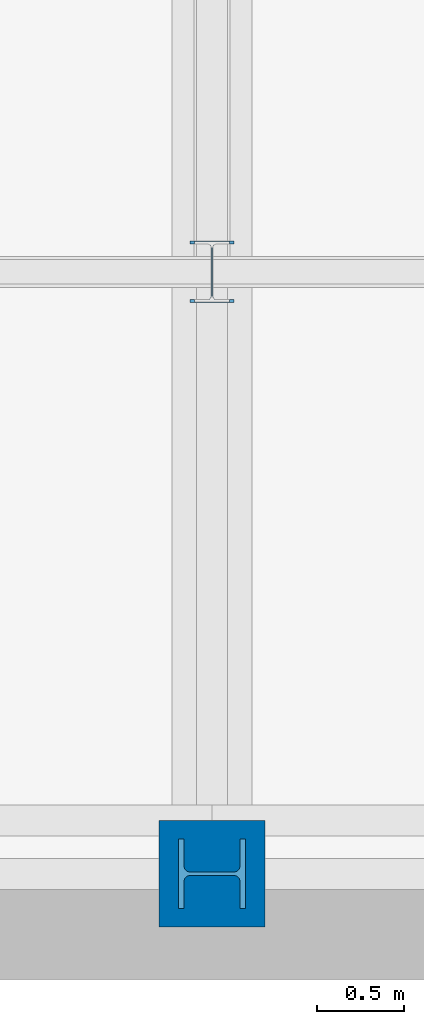
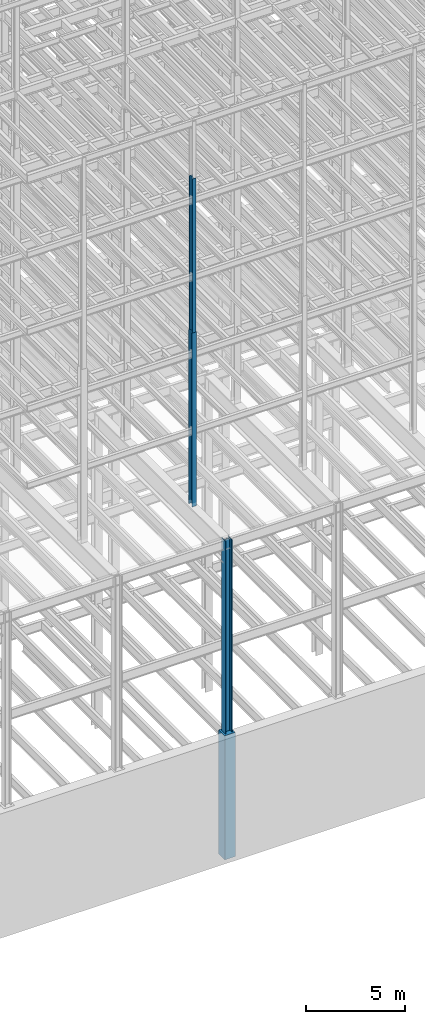
# One storey, part 5 of 150: 4 columns.
"""IFC2X3 building model written with IfcOpenShell, lengths in millimetres."""

from ifc_helpers import new_model, si_unit, frame, origin_with_axes, origin_2d_with_axis, place, context, subcontext, project, spatial, rectangle, i_section, extrude, material, type_object, element, save


model = new_model("IFC2X3")

# Units and contexts
model_context = context("Model", 3, precision=1e-05, world=origin_with_axes())
body_context = subcontext(model_context, "Body", "Model", "MODEL_VIEW")
ifc_project = project(units=[si_unit("LENGTHUNIT", "METRE", prefix="MILLI"), si_unit("AREAUNIT", "SQUARE_METRE"), si_unit("VOLUMEUNIT", "CUBIC_METRE"), si_unit("MASSUNIT", "GRAM", prefix="KILO"), si_unit("TIMEUNIT", "SECOND"), si_unit("PLANEANGLEUNIT", "RADIAN"), si_unit("SOLIDANGLEUNIT", "STERADIAN"), si_unit("THERMODYNAMICTEMPERATUREUNIT", "DEGREE_CELSIUS"), si_unit("LUMINOUSINTENSITYUNIT", "LUMEN")], contexts=[model_context])

# Site, building, storey
site_placement = place(None, origin_with_axes())
site = spatial("IfcSite", under=ifc_project, at=site_placement, CompositionType="ELEMENT")
building_placement = place(site_placement, origin_with_axes())
building = spatial("IfcBuilding", under=site, at=building_placement, Name="Undefined", CompositionType="ELEMENT")
storey_placement = place(building_placement, origin_with_axes())
storey = spatial("IfcBuildingStorey", under=building, at=storey_placement, Name="Undefined", CompositionType="ELEMENT", Elevation=0.0)

# Columns
ifc_material_1 = material(Name="STEEL/A992")
column_type_1 = type_object("IfcColumnType", Name="W14X53", PredefinedType="NOTDEFINED")
column_1_placement = place(storey_placement, frame((24587.2, 3454.39999999999, 46253.4), z_axis=(0.0, 0.0, 1.0), x_axis=(1.0, 0.0, 0.0)))
element("IfcColumn", 1, at=column_1_placement, inside=storey, type_object=column_type_1, material=ifc_material_1, Name="COLUMN", ObjectType="W14X53", context=body_context, shape_type="SweptSolid", body=[
    extrude(i_section(OverallWidth=203.2, OverallDepth=352.425, WebThickness=9.5249, FlangeThickness=16.764, FilletRadius=21.336, at=origin_2d_with_axis()), frame((0.0, 0.0, 9448.8), z_axis=(0.0, 0.0, -1.0), x_axis=(-1.0, 0.0, 0.0)), (0.0, 0.0, 1.0), 9448.8),
])
column_type_2 = type_object("IfcColumnType", Name="W14X61", PredefinedType="NOTDEFINED")
column_2_placement = place(storey_placement, frame((24587.2, 3454.39999999999, 35585.4), z_axis=(0.0, 0.0, 1.0), x_axis=(1.0, 0.0, 0.0)))
element("IfcColumn", 2, at=column_2_placement, inside=storey, type_object=column_type_2, material=ifc_material_1, Name="COLUMN", ObjectType="W14X61", context=body_context, shape_type="SweptSolid", body=[
    extrude(i_section(OverallWidth=254.0, OverallDepth=352.425, WebThickness=9.5249, FlangeThickness=16.383, FilletRadius=21.717, at=origin_2d_with_axis()), frame((0.0, 0.0, 10668.0), z_axis=(0.0, 0.0, -1.0), x_axis=(-1.0, 0.0, 0.0)), (0.0, 0.0, 1.0), 10668.0),
])
column_type_3 = type_object("IfcColumnType", Name="W14X176", PredefinedType="NOTDEFINED")
column_3_placement = place(storey_placement, frame((24587.2, 0.0, 22707.6), z_axis=(0.0, 0.0, 1.0), x_axis=(1.0, 0.0, 0.0)))
element("IfcColumn", 3, at=column_3_placement, inside=storey, type_object=column_type_3, material=ifc_material_1, Name="COLUMN", ObjectType="W14X176", context=body_context, shape_type="SweptSolid", body=[
    extrude(i_section(OverallWidth=396.875, OverallDepth=387.35, WebThickness=20.6375, FlangeThickness=33.274, FilletRadius=33.401, at=origin_2d_with_axis()), frame((0.0, 0.0, 12877.8), z_axis=(0.0, 0.0, -1.0), x_axis=(0.0, -1.0, 0.0)), (0.0, 0.0, 1.0), 12877.8),
])
ifc_material_2 = material(Name="CONCRETE/5000")
column_type_4 = type_object("IfcColumnType", PredefinedType="NOTDEFINED")
column_4_placement = place(storey_placement, frame((24587.2, 0.0, 16154.4), z_axis=(0.0, 0.0, 1.0), x_axis=(1.0, 0.0, 0.0)))
element("IfcColumn", 4, at=column_4_placement, inside=storey, type_object=column_type_4, material=ifc_material_2, Name="COLUMN", context=body_context, shape_type="SweptSolid", body=[
    extrude(rectangle(XDim=609.6, YDim=609.6, at=origin_2d_with_axis()), frame((0.0, 0.0, 7620.0), z_axis=(0.0, 0.0, -1.0), x_axis=(0.0, -1.0, 0.0)), (0.0, 0.0, 1.0), 7620.0),
])

save(model, "model.ifc")
